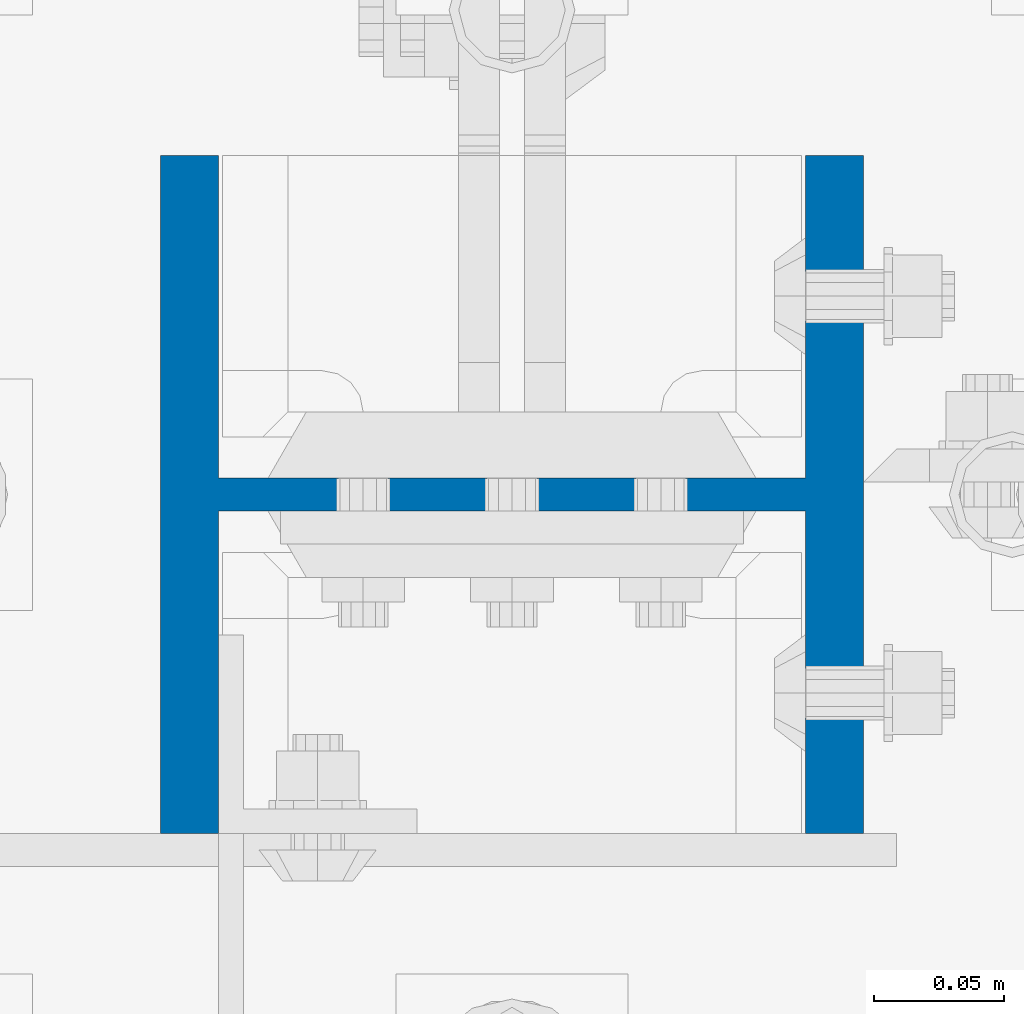
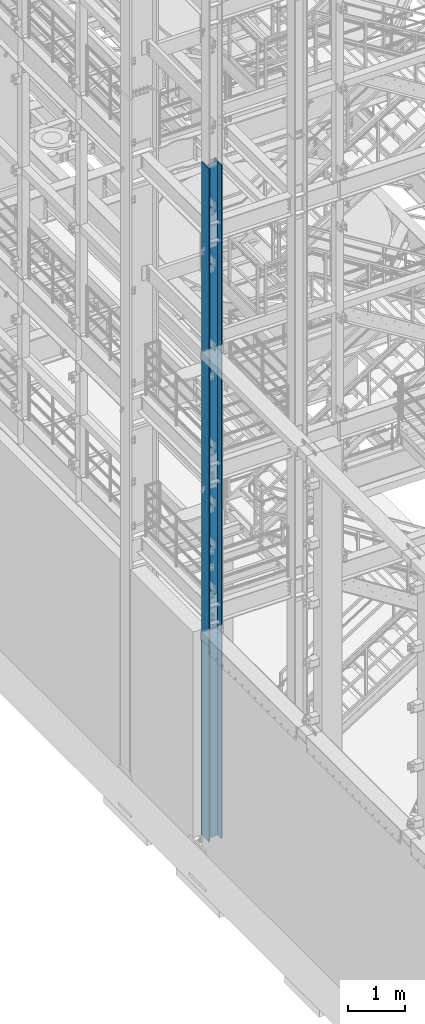
# One storey, part 559 of 1876: 1 column, 1 element without a shape of its own.
"""IFC2X3 building model written with IfcOpenShell, lengths in millimetres."""

from ifc_helpers import new_model, si_unit, frame, origin_with_axes, place, context, subcontext, project, spatial, faceted_brep, material, type_object, element, aggregate, save


model = new_model("IFC2X3")

# Units and contexts
model_context = context("Model", 3, precision=1e-05, world=origin_with_axes())
body_context = subcontext(model_context, "Body", "Model", "MODEL_VIEW")
ifc_project = project(units=[si_unit("LENGTHUNIT", "METRE", prefix="MILLI"), si_unit("AREAUNIT", "SQUARE_METRE"), si_unit("VOLUMEUNIT", "CUBIC_METRE"), si_unit("MASSUNIT", "GRAM", prefix="KILO"), si_unit("TIMEUNIT", "SECOND"), si_unit("PLANEANGLEUNIT", "RADIAN"), si_unit("SOLIDANGLEUNIT", "STERADIAN"), si_unit("THERMODYNAMICTEMPERATUREUNIT", "DEGREE_CELSIUS"), si_unit("LUMINOUSINTENSITYUNIT", "LUMEN")], contexts=[model_context])

# Site, building, storey
site_placement = place(None, origin_with_axes())
site = spatial("IfcSite", under=ifc_project, at=site_placement, CompositionType="ELEMENT")
building_placement = place(site_placement, origin_with_axes())
building = spatial("IfcBuilding", under=site, at=building_placement, Name="Undefined", CompositionType="ELEMENT")
storey_placement = place(building_placement, origin_with_axes())
storey = spatial("IfcBuildingStorey", under=building, at=storey_placement, Name="Undefined", CompositionType="ELEMENT", Elevation=0.0)

# Assembly, column
assembly_placement = place(storey_placement, origin_with_axes())
assembly = element("IfcElementAssembly", 1, at=assembly_placement, inside=storey, Name="COLUMN", AssemblyPlace="NOTDEFINED", PredefinedType="RIGID_FRAME")
ifc_material = material(Name="STEEL/A992")
column_type = type_object("IfcColumnType", Name="W10X77", PredefinedType="NOTDEFINED")
column_placement = place(assembly_placement, frame((0.0, -7112.0, 0.0), z_axis=(-1.0, 0.0, 0.0), x_axis=(0.0, 0.0, 1.0)))
column = element("IfcColumn", 2, at=column_placement, type_object=column_type, material=ifc_material, Name="COLUMN", ObjectType="W10X77", context=body_context, shape_type="Brep", body=[
    faceted_brep([(107.95, -6.35000000000036, 88.5755937151584), (101.600000762938, -7.6293963502394e-07, 87.3125003340556), (95.25, 6.35000000000036, 87.3125003340556), (95.25, 6.35000000000036, -87.3125003814696), (101.600000762939, -7.62940544518642e-07, -87.3125003814696), (107.95, -6.35000000000036, -88.5755937625725), (14528.8, -130.175, 134.9375), (14528.8, 130.175, 134.9375), (117.475, 130.175, 134.9375), (117.475, -130.175, 134.9375), (120.649999999998, -130.175, 112.7125), (14497.05, -130.175, 112.7125), (14528.8, -130.175, 112.7125), (95.25, -130.175, 112.7125), (120.649999999999, -6.35000000000036, 112.712499952586), (14497.05, -6.35000000000036, 112.7125), (14528.8, -6.35000000000036, 112.7125), (95.25, -6.35000000000036, 112.7125), (14528.8, -130.175, -134.9375), (14528.8, -130.175, -112.7125), (14497.05, -130.175, -112.7125), (120.649999999998, -130.175, -112.7125), (95.25, -130.175, -112.7125), (117.475, -130.175, -134.9375), (14528.8, 130.175, -134.9375), (117.475, 130.175, -134.9375), (120.649999999998, 130.175, -112.7125), (14497.05, 130.175, -112.7125), (14528.8, 130.175, -112.7125), (95.25, 130.175, -112.7125), (14528.8, 6.35000000000036, -112.7125), (14528.8, -6.35000000000036, -112.7125), (14497.05, -6.35000000000036, -112.7125), (120.649999999998, -6.35000000000036, -112.7125), (95.25, -6.35000000000036, -112.7125), (108.89011985753, -6.35000000000036, -88.7625952290543), (108.89011985753, 6.35000000000036, -88.7625952290543), (115.070384405063, 6.35000000000036, -92.8921159764066), (115.070384405063, -6.35000000000036, -92.8921159764066), (119.199905152415, 6.35000000000036, -99.0723805239406), (119.199905152415, -6.35000000000036, -99.0723805239406), (120.649999999999, 6.35000000000036, -106.362499618532), (120.649999999999, -6.35000000000036, -106.362499618532), (120.649999999998, 6.35000000000036, -112.7125), (95.25, 6.35000000000036, -112.7125), (14497.05, 6.35000000000036, -112.7125), (14498.6039556076, 6.35000000000036, -102.901210428596), (14498.6039556076, -6.35000000000036, -102.901210428596), (14503.1137104286, 6.35000000000036, -94.050318239714), (14503.1137104286, -6.35000000000036, -94.050318239714), (14510.1378182397, 6.35000000000036, -87.0262104285955), (14510.1378182397, -6.35000000000036, -87.0262104285955), (14518.9887104286, 6.35000000000036, -82.516455607629), (14518.9887104286, -6.35000000000036, -82.516455607629), (14528.8, -6.35000000000036, -80.9625000000001), (14528.8, 6.35000000000036, -80.9625000000001), (14528.8, 6.35000000000036, 80.9625000000001), (14528.8, -6.35000000000036, 80.9625000000001), (14518.9887104286, 6.35000000000036, 82.516455607629), (14518.9887104286, -6.35000000000036, 82.516455607629), (14510.1378182397, 6.35000000000036, 87.0262104285955), (14510.1378182397, -6.35000000000036, 87.0262104285955), (14503.1137104286, 6.35000000000036, 94.050318239714), (14503.1137104286, -6.35000000000036, 94.050318239714), (14498.6039556076, 6.35000000000036, 102.901210428596), (14498.6039556076, -6.35000000000036, 102.901210428596), (14497.05, 6.35000000000036, 112.7125), (14528.8, 6.35000000000036, 112.7125), (14528.8, 130.175, 112.7125), (14497.05, 130.175, 112.7125), (120.649999999998, 130.175, 112.7125), (95.25, 130.175, 112.7125), (95.25, 6.35000000000036, 112.7125), (120.649999999998, 6.35000000000036, 112.7125), (120.649999999999, 6.35000000000036, 106.362499571116), (120.649999999999, -6.35000000000036, 106.362499571116), (119.199905152414, 6.35000000000036, 99.0723804765255), (119.199905152414, -6.35000000000036, 99.0723804765255), (115.070384405062, 6.35000000000036, 92.8921159289921), (115.070384405062, -6.35000000000036, 92.8921159289921), (108.890119857529, 6.35000000000036, 88.7625951816403), (108.890119857529, -6.35000000000036, 88.7625951816403), (101.600000762939, 6.35000000000036, -87.3125003814696), (101.600000762938, 6.35000000000036, 87.3125003340556)], [[[0, 1, 2, 3, 4, 5]], [[6, 7, 8, 9]], [[10, 11, 12, 6, 9, 13]], [[14, 15, 16, 12, 11, 10, 13, 17]], [[18, 19, 20, 21, 22, 23]], [[24, 18, 23, 25]], [[26, 27, 28, 24, 25, 29]], [[19, 18, 24, 28, 30, 31]], [[21, 20, 19, 31, 32, 33, 34, 22]], [[35, 36, 37, 38]], [[38, 37, 39, 40]], [[40, 39, 41, 42]], [[42, 41, 43, 33]], [[33, 43, 44, 34]], [[29, 25, 23, 22, 34, 44]], [[43, 45, 30, 28, 27, 26, 29, 44]], [[31, 30, 45, 32]], [[32, 45, 46, 47]], [[47, 46, 48, 49]], [[49, 48, 50, 51]], [[51, 50, 52, 53]], [[54, 53, 52, 55]], [[56, 57, 54, 55]], [[57, 56, 58, 59]], [[59, 58, 60, 61]], [[61, 60, 62, 63]], [[63, 62, 64, 65]], [[65, 64, 66, 15]], [[16, 15, 66, 67]], [[68, 7, 6, 12, 16, 67]], [[7, 68, 69, 70, 71, 8]], [[13, 9, 8, 71, 72, 17]], [[70, 69, 68, 67, 66, 73, 72, 71]], [[17, 72, 73, 14]], [[14, 73, 74, 75]], [[75, 74, 76, 77]], [[77, 76, 78, 79]], [[79, 78, 80, 81]], [[35, 38, 40, 42, 33, 32, 47, 49, 51, 53, 54, 57, 59, 61, 63, 65, 15, 14, 75, 77, 79, 81, 0, 5]], [[82, 36, 35, 5, 4]], [[82, 4, 3]], [[83, 80, 78, 76, 74, 73, 66, 64, 62, 60, 58, 56, 55, 52, 50, 48, 46, 45, 43, 41, 39, 37, 36, 82, 3, 2]], [[83, 2, 1]], [[81, 80, 83, 1, 0]]]),
])
aggregate(assembly, [column])

save(model, "model.ifc")
